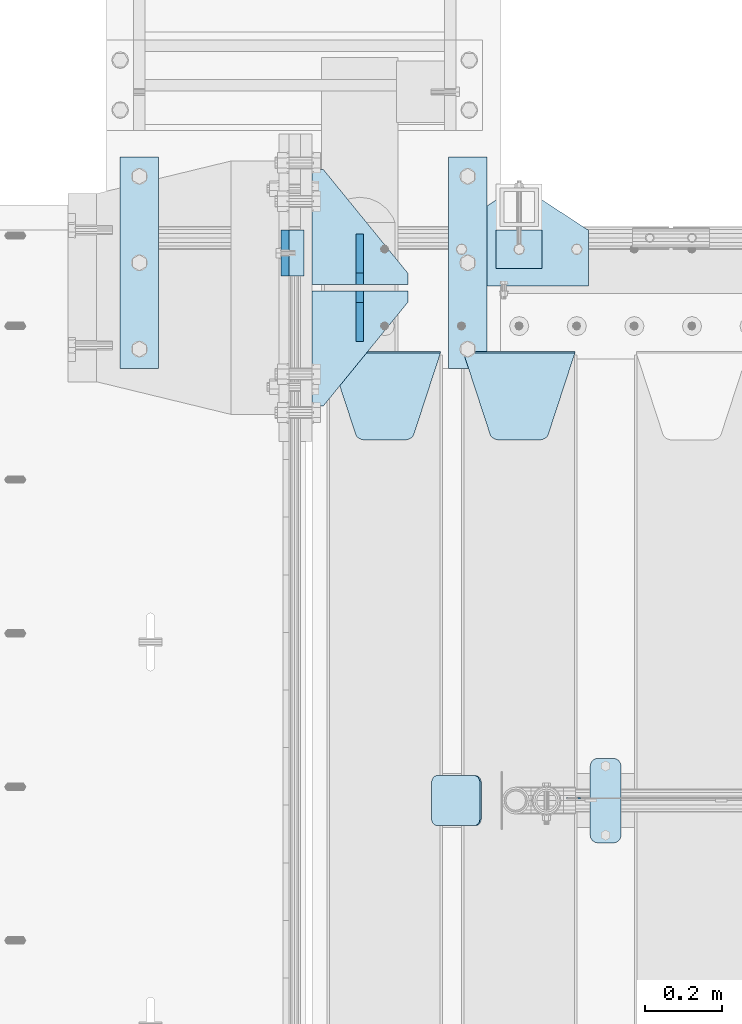
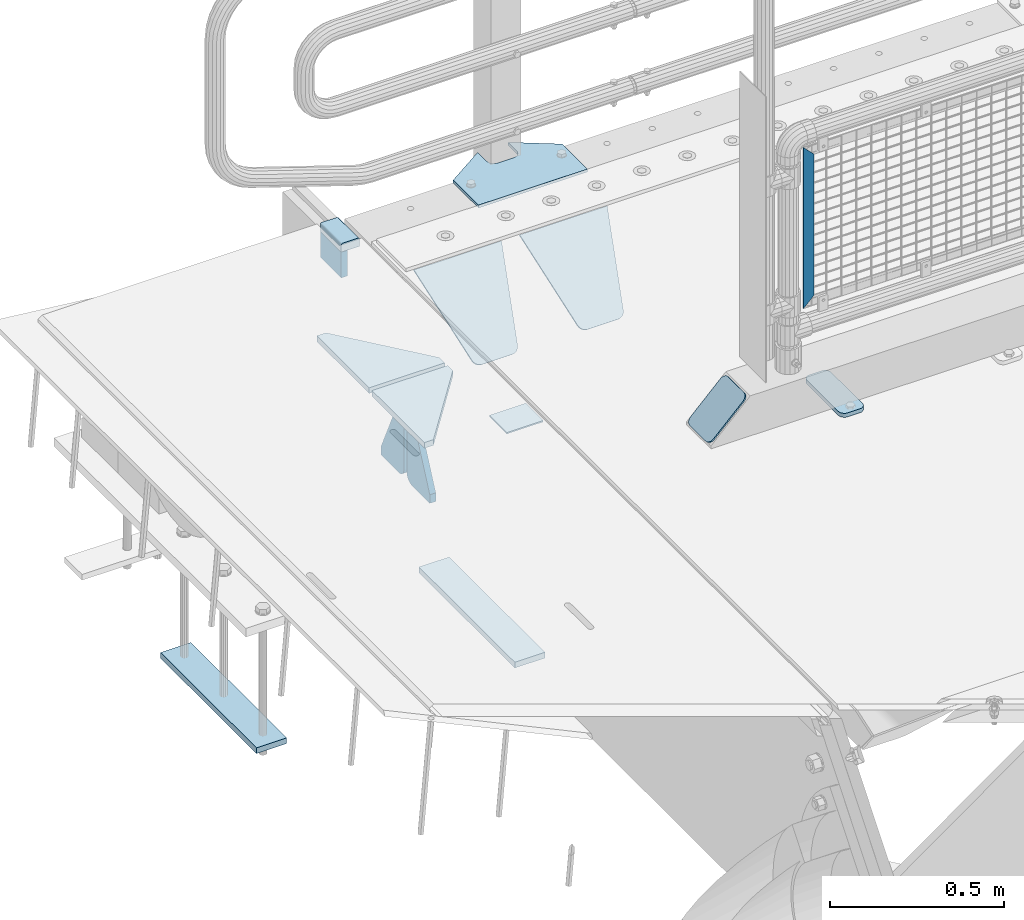
# One storey, part 212 of 247: 15 plates.
"""IFC2X3 building model written with IfcOpenShell, lengths in millimetres."""

from ifc_helpers import new_model, si_unit, frame, origin_with_axes, place, context, subcontext, project, spatial, faceted_brep, material, type_object, element, save


model = new_model("IFC2X3")

# Units and contexts
model_context = context("Model", 3, precision=1e-05, world=origin_with_axes())
body_context = subcontext(model_context, "Body", "Model", "MODEL_VIEW")
ifc_project = project(units=[si_unit("LENGTHUNIT", "METRE", prefix="MILLI"), si_unit("AREAUNIT", "SQUARE_METRE"), si_unit("VOLUMEUNIT", "CUBIC_METRE"), si_unit("MASSUNIT", "GRAM", prefix="KILO"), si_unit("TIMEUNIT", "SECOND"), si_unit("PLANEANGLEUNIT", "RADIAN"), si_unit("SOLIDANGLEUNIT", "STERADIAN"), si_unit("THERMODYNAMICTEMPERATUREUNIT", "DEGREE_CELSIUS"), si_unit("LUMINOUSINTENSITYUNIT", "LUMEN")], contexts=[model_context])

# Site, building, storey
site_placement = place(None, origin_with_axes())
site = spatial("IfcSite", under=ifc_project, at=site_placement, CompositionType="ELEMENT")
building_placement = place(site_placement, origin_with_axes())
building = spatial("IfcBuilding", under=site, at=building_placement, Name="Standard", CompositionType="ELEMENT")
storey_placement = place(building_placement, origin_with_axes())
storey = spatial("IfcBuildingStorey", under=building, at=storey_placement, Name="Undefined", CompositionType="ELEMENT", Elevation=0.0)

# Plates
ifc_material_1 = material()
plate_type_1 = type_object("IfcPlateType", PredefinedType="NOTDEFINED")
plate_1_placement = place(storey_placement, frame((-9.99999999999636, 9090.00000000002, -16.0000571412541), z_axis=(-1.0, 0.0, 0.0), x_axis=(0.0, 0.0, 1.0)))
element("IfcPlate", 1, at=plate_1_placement, inside=storey, type_object=plate_type_1, material=ifc_material_1, context=body_context, shape_type="Brep", body=[
    faceted_brep([(0.0, -59.9999999999991, 0.0), (2.49929144047201e-09, -59.9999999999991, 60.0), (2.49928788775833e-09, 60.0000000000005, 60.0), (-3.5527136788005e-15, 60.0000000000005, 0.0), (25.0146748218828, -59.9999999999991, 60.0), (25.0146748218828, 60.0000000000005, 60.0), (26.5597449794466, -59.9999999999991, 59.7552873949117), (26.5597449794466, 60.0000000000005, 59.7552873949117), (27.9535758796897, -59.9999999999991, 59.0451032832824), (27.9535758796897, 60.0000000000009, 59.0451032832824), (29.0597323263517, -59.9999999999991, 57.9389640667317), (29.0597323263517, 60.0000000000005, 57.9389640667317), (29.7699381491534, -59.9999999999991, 56.5451442289687), (29.7699381491534, 60.0000000000009, 56.5451442289687), (30.0146748212762, -59.9999999999991, 55.0000778834025), (30.0146748212762, 60.0000000000009, 55.0000778834025), (30.0154536553013, -59.9999999999991, 5.00007788340855), (30.0154536553013, 60.0000000000005, 5.00007788340855), (29.7707554908505, -59.9999999999991, 3.45497428546548), (29.7707554908505, 60.0000000000009, 3.45497428546548), (29.0605660948355, -59.9999999999991, 2.06111154407017), (29.0605660948355, 60.0000000000009, 2.06111154407017), (27.9544051209123, -59.9999999999991, 0.954933339696428), (27.9544051209123, 60.0000000000009, 0.954933339696428), (26.5605534420796, -59.9999999999991, 0.244722232012666), (26.5605534420796, 60.0000000000009, 0.244722232012666), (25.0154536559091, -59.9999999999986, 6.05382410867605e-12), (25.0154536559091, 60.0000000000009, 6.05382410867605e-12)], [[[0, 1, 2, 3]], [[1, 4, 5, 2]], [[4, 6, 7, 5]], [[6, 8, 9, 7]], [[8, 10, 11, 9]], [[10, 12, 13, 11]], [[12, 14, 15, 13]], [[14, 16, 17, 15]], [[16, 18, 19, 17]], [[18, 20, 21, 19]], [[20, 22, 23, 21]], [[22, 24, 25, 23]], [[24, 26, 27, 25]], [[26, 0, 3, 27]], [[5, 7, 9, 11, 13, 15, 17, 19, 21, 23, 25, 27, 3, 2]], [[26, 24, 22, 20, 18, 16, 14, 12, 10, 8, 6, 4, 1, 0]]]),
])
ifc_material_2 = material(Name="STEEL/S355N")
plate_type_2 = type_object("IfcPlateType", PredefinedType="NOTDEFINED")
plate_2_placement = place(storey_placement, frame((-60.0, 9150.00008553446, -105.984391681369), z_axis=(0.0, -0.999999999999548, -9.5100000000016e-07), x_axis=(0.0, 0.0, 1.0)))
element("IfcPlate", 2, at=plate_2_placement, inside=storey, type_object=plate_type_2, material=ifc_material_2, context=body_context, shape_type="Brep", body=[
    faceted_brep([(-5.6843418860808e-14, -9.99999999999989, 3.5527136788005e-15), (4.32933688898629e-10, -10.0, 120.0), (4.32933688898629e-10, 10.0, 120.0), (-5.6843418860808e-14, 10.0000000000001, 3.5527136788005e-15), (89.9845046997072, -10.0, 120.0), (89.9845046997072, 10.0, 120.0), (89.9843902587891, -10.0, 6.54836185276508e-11), (89.9843902587891, 10.0, 6.54836185276508e-11)], [[[0, 1, 2, 3]], [[1, 4, 5, 2]], [[4, 6, 7, 5]], [[6, 0, 3, 7]], [[5, 7, 3, 2]], [[6, 4, 1, 0]]]),
])
ifc_material_3 = material(Name="STEEL/S355J2")
plate_type_3 = type_object("IfcPlateType", PredefinedType="NOTDEFINED")
plate_3_placement = place(storey_placement, frame((735.0, 7774.5, 21.0199999999977), z_axis=(1.0, 0.0, 0.0), x_axis=(0.0, -0.999999999999548, -9.5100000000016e-07)))
element("IfcPlate", 3, at=plate_3_placement, inside=storey, type_object=plate_type_3, material=ifc_material_3, context=body_context, shape_type="Brep", body=[
    faceted_brep([(0.0, -7.0, 20.0), (0.0, -7.0, 60.0), (0.0, 7.0, 60.0), (0.0, 7.0, 20.0), (0.384294391935327, -7.0, 63.9018064403226), (0.384294391935327, 7.0, 63.9018064403226), (1.52240934977453, -7.0, 67.6536686473009), (1.52240934977453, 7.0, 67.6536686473009), (3.37060775394912, -7.0, 71.1114046603925), (3.37060775394912, 7.0, 71.1114046603925), (5.85786437626939, -7.0, 74.1421356237315), (5.85786437626939, 7.0, 74.1421356237315), (8.8885953396084, -7.0, 76.6293922460518), (8.8885953396084, 7.0, 76.6293922460518), (12.3463313526981, -7.0, 78.4775906502255), (12.3463313526981, 7.0, 78.4775906502255), (16.0981935596774, -7.0, 79.6157056080647), (16.0981935596774, 7.0, 79.6157056080647), (20.0, -7.0, 80.0), (20.0, 7.0, 80.0), (200.0, -7.0, 80.0), (200.0, 7.0, 80.0), (203.901806440323, -7.0, 79.6157056080647), (203.901806440323, 7.0, 79.6157056080647), (207.653668647302, -7.0, 78.4775906502255), (207.653668647302, 7.0, 78.4775906502255), (211.111404660392, -7.0, 76.6293922460518), (211.111404660392, 7.0, 76.6293922460518), (214.142135623731, -7.0, 74.1421356237315), (214.142135623731, 7.0, 74.1421356237315), (216.629392246051, -7.0, 71.1114046603925), (216.629392246051, 7.0, 71.1114046603925), (218.477590650225, -7.0, 67.6536686473009), (218.477590650225, 7.0, 67.6536686473009), (219.615705608065, -7.0, 63.9018064403226), (219.615705608065, 7.0, 63.9018064403226), (220.0, -7.0, 60.0), (220.0, 7.0, 60.0), (220.0, -7.0, 20.0), (220.0, 7.0, 20.0), (219.615705608065, -7.0, 16.0981935596774), (219.615705608065, 7.0, 16.0981935596774), (218.477590650225, -7.0, 12.3463313526991), (218.477590650225, 7.0, 12.3463313526991), (216.629392246051, -7.0, 8.88859533960749), (216.629392246051, 7.0, 8.88859533960749), (214.142135623731, -7.0, 5.85786437626848), (214.142135623731, 7.0, 5.85786437626848), (211.111404660392, -7.0, 3.37060775394821), (211.111404660392, 7.0, 3.37060775394821), (207.653668647302, -7.0, 1.52240934977453), (207.653668647302, 7.0, 1.52240934977453), (203.901806440323, -7.0, 0.384294391935327), (203.901806440323, 7.0, 0.384294391935327), (200.0, -7.0, 0.0), (200.0, 7.0, 0.0), (20.0, -7.0, 0.0), (20.0, 7.0, 0.0), (16.0981935596774, -7.0, 0.384294391935327), (16.0981935596774, 7.0, 0.384294391935327), (12.3463313526981, -7.0, 1.52240934977453), (12.3463313526981, 7.0, 1.52240934977453), (8.8885953396084, -7.0, 3.37060775394821), (8.8885953396084, 7.0, 3.37060775394821), (5.85786437626939, -7.0, 5.85786437626848), (5.85786437626939, 7.0, 5.85786437626848), (3.37060775394912, -7.0, 8.88859533960749), (3.37060775394912, 7.0, 8.88859533960749), (1.52240934977453, -7.0, 12.3463313526991), (1.52240934977453, 7.0, 12.3463313526991), (0.384294391935327, -7.0, 16.0981935596774), (0.384294391935327, 7.0, 16.0981935596774)], [[[0, 1, 2, 3]], [[1, 4, 5, 2]], [[4, 6, 7, 5]], [[6, 8, 9, 7]], [[8, 10, 11, 9]], [[10, 12, 13, 11]], [[12, 14, 15, 13]], [[14, 16, 17, 15]], [[16, 18, 19, 17]], [[18, 20, 21, 19]], [[20, 22, 23, 21]], [[22, 24, 25, 23]], [[24, 26, 27, 25]], [[26, 28, 29, 27]], [[28, 30, 31, 29]], [[30, 32, 33, 31]], [[32, 34, 35, 33]], [[34, 36, 37, 35]], [[36, 38, 39, 37]], [[38, 40, 41, 39]], [[40, 42, 43, 41]], [[42, 44, 45, 43]], [[44, 46, 47, 45]], [[46, 48, 49, 47]], [[48, 50, 51, 49]], [[50, 52, 53, 51]], [[52, 54, 55, 53]], [[54, 56, 57, 55]], [[56, 58, 59, 57]], [[58, 60, 61, 59]], [[60, 62, 63, 61]], [[62, 64, 65, 63]], [[64, 66, 67, 65]], [[66, 68, 69, 67]], [[68, 70, 71, 69]], [[70, 0, 3, 71]], [[5, 7, 9, 11, 13, 15, 17, 19, 21, 23, 25, 27, 29, 31, 33, 35, 37, 39, 41, 43, 45, 47, 49, 51, 53, 55, 57, 59, 61, 63, 65, 67, 69, 71, 3, 2]], [[70, 68, 66, 64, 62, 60, 58, 56, 54, 52, 50, 48, 46, 44, 42, 40, 38, 36, 34, 32, 30, 28, 26, 24, 22, 20, 18, 16, 14, 12, 10, 8, 6, 4, 1, 0]]]),
])
plate_type_4 = type_object("IfcPlateType", PredefinedType="NOTDEFINED")
plate_4_placement = place(storey_placement, frame((405.0, 8831.76776695594, -1.767766952965), z_axis=(0.0, -0.707106781186548, -0.707106781186547), x_axis=(1.0, 0.0, 0.0)))
element("IfcPlate", 4, at=plate_4_placement, inside=storey, type_object=plate_type_4, material=ifc_material_2, context=body_context, shape_type="Brep", body=[
    faceted_brep([(0.0, -2.49999999999909, 0.0), (69.345504679477, -2.5, 300.17173142483), (69.345504679477, 2.50000000000091, 300.171731424831), (0.0, 2.5, -9.09494701772928e-13), (70.9274061199576, -2.5, 304.897442415399), (70.9274061199576, 2.50000000000091, 304.8974424154), (73.3818627772307, -2.49999999999909, 309.234538108527), (73.3818627772307, 2.5, 309.234538108526), (76.6187032999551, -2.5, 313.023683126102), (76.6187032999551, 2.50000000000091, 313.023683126102), (80.5190132704993, -2.49999999999909, 316.125672595371), (80.5190132704993, 2.50000000000091, 316.125672595372), (84.9395038596849, -2.49999999999909, 318.426546230476), (84.9395038596849, 2.5, 318.426546230475), (89.7177759439219, -2.5, 319.841774983274), (89.7177759439219, 2.50000000000091, 319.841774983275), (94.678286292652, -2.5, 320.319366455077), (94.678286292652, 2.50000000000091, 320.319366455077), (195.321713707348, -2.5, 320.319366455077), (195.321713707348, 2.50000000000091, 320.319366455077), (200.282224056078, -2.5, 319.841774983274), (200.282224056078, 2.50000000000091, 319.841774983275), (205.060496140315, -2.5, 318.426546230475), (205.060496140315, 2.5, 318.426546230474), (209.480986729501, -2.49999999999818, 316.12567259537), (209.480986729501, 2.50000000000091, 316.12567259537), (213.381296700045, -2.5, 313.023683126101), (213.381296700045, 2.50000000000091, 313.023683126101), (216.618137222769, -2.5, 309.234538108525), (216.618137222769, 2.5, 309.234538108525), (219.072593880042, -2.49999999999909, 304.897442415398), (219.072593880042, 2.5, 304.897442415398), (220.654495320523, -2.5, 300.17173142483), (220.654495320523, 2.50000000000091, 300.171731424831), (290.0, -2.49999999999909, 0.0), (290.0, 2.5, -9.09494701772928e-13)], [[[0, 1, 2, 3]], [[1, 4, 5, 2]], [[4, 6, 7, 5]], [[6, 8, 9, 7]], [[8, 10, 11, 9]], [[10, 12, 13, 11]], [[12, 14, 15, 13]], [[14, 16, 17, 15]], [[16, 18, 19, 17]], [[18, 20, 21, 19]], [[20, 22, 23, 21]], [[22, 24, 25, 23]], [[24, 26, 27, 25]], [[26, 28, 29, 27]], [[28, 30, 31, 29]], [[30, 32, 33, 31]], [[32, 34, 35, 33]], [[34, 0, 3, 35]], [[5, 7, 9, 11, 13, 15, 17, 19, 21, 23, 25, 27, 29, 31, 33, 35, 3, 2]], [[34, 32, 30, 28, 26, 24, 22, 20, 18, 16, 14, 12, 10, 8, 6, 4, 1, 0]]]),
])
plate_5_placement = place(storey_placement, frame((55.0, 8831.76776695594, -1.767766952965), z_axis=(0.0, -0.707106781186548, -0.707106781186547), x_axis=(1.0, 0.0, 0.0)))
element("IfcPlate", 5, at=plate_5_placement, inside=storey, type_object=plate_type_4, material=ifc_material_2, context=body_context, shape_type="Brep", body=[
    faceted_brep([(0.0, -2.49999999999909, 0.0), (69.345504679477, -2.5, 300.17173142483), (69.345504679477, 2.50000000000091, 300.171731424831), (0.0, 2.5, -9.09494701772928e-13), (70.9274061199576, -2.5, 304.897442415399), (70.9274061199576, 2.50000000000091, 304.8974424154), (73.3818627772307, -2.49999999999909, 309.234538108527), (73.3818627772307, 2.5, 309.234538108526), (76.6187032999551, -2.5, 313.023683126102), (76.6187032999551, 2.50000000000091, 313.023683126102), (80.5190132704993, -2.49999999999909, 316.125672595371), (80.5190132704993, 2.50000000000091, 316.125672595372), (84.9395038596849, -2.49999999999909, 318.426546230476), (84.9395038596849, 2.5, 318.426546230475), (89.7177759439219, -2.5, 319.841774983274), (89.7177759439219, 2.50000000000091, 319.841774983275), (94.678286292652, -2.5, 320.319366455077), (94.678286292652, 2.50000000000091, 320.319366455077), (195.321713707348, -2.5, 320.319366455077), (195.321713707348, 2.50000000000091, 320.319366455077), (200.282224056078, -2.5, 319.841774983274), (200.282224056078, 2.50000000000091, 319.841774983275), (205.060496140315, -2.5, 318.426546230475), (205.060496140315, 2.5, 318.426546230474), (209.480986729501, -2.49999999999818, 316.12567259537), (209.480986729501, 2.50000000000091, 316.12567259537), (213.381296700045, -2.5, 313.023683126101), (213.381296700045, 2.50000000000091, 313.023683126101), (216.618137222769, -2.5, 309.234538108525), (216.618137222769, 2.5, 309.234538108525), (219.072593880042, -2.49999999999909, 304.897442415398), (219.072593880042, 2.5, 304.897442415398), (220.654495320523, -2.5, 300.17173142483), (220.654495320523, 2.50000000000091, 300.171731424831), (290.0, -2.49999999999909, 0.0), (290.0, 2.5, -9.09494701772928e-13)], [[[0, 1, 2, 3]], [[1, 4, 5, 2]], [[4, 6, 7, 5]], [[6, 8, 9, 7]], [[8, 10, 11, 9]], [[10, 12, 13, 11]], [[12, 14, 15, 13]], [[14, 16, 17, 15]], [[16, 18, 19, 17]], [[18, 20, 21, 19]], [[20, 22, 23, 21]], [[22, 24, 25, 23]], [[24, 26, 27, 25]], [[26, 28, 29, 27]], [[28, 30, 31, 29]], [[30, 32, 33, 31]], [[32, 34, 35, 33]], [[34, 0, 3, 35]], [[5, 7, 9, 11, 13, 15, 17, 19, 21, 23, 25, 27, 29, 31, 33, 35, 3, 2]], [[34, 32, 30, 28, 26, 24, 22, 20, 18, 16, 14, 12, 10, 8, 6, 4, 1, 0]]]),
])
plate_type_5 = type_object("IfcPlateType", PredefinedType="NOTDEFINED")
for number, where, z_axis, x_axis in (
    (6, (-488.999999999987, 9339.99999928438, -1468.0), (0.0, -0.999999999999548, -9.5100000000016e-07), (1.0, 0.0, 0.0)),
    (7, (366.000000000013, 9340.00000013937, -1468.0), (0.0, -0.999999999999548, -9.5100000000016e-07), (1.0, 0.0, 0.0)),
):
    element("IfcPlate", number, at=place(storey_placement, frame(where, z_axis=z_axis, x_axis=x_axis)), inside=storey, type_object=plate_type_5, material=ifc_material_2, context=body_context, shape_type="Brep", body=[
        faceted_brep([(-5.6843418860808e-14, -9.99999999999989, 3.5527136788005e-15), (1.00943600500614e-06, -10.0, 550.0), (1.00943600500614e-06, 10.0, 550.0), (-5.6843418860808e-14, 10.0000000000001, 3.5527136788005e-15), (100.000000000004, -10.0, 550.0), (100.000000000004, 10.0, 550.0), (100.0, -10.0, 0.0), (100.0, 10.0, 0.0)], [[[0, 1, 2, 3]], [[1, 4, 5, 2]], [[4, 6, 7, 5]], [[6, 0, 3, 7]], [[5, 7, 3, 2]], [[6, 4, 1, 0]]]),
    ])
ifc_material_4 = material(Name="Misc_Undefined")
plate_type_6 = type_object("IfcPlateType", PredefinedType="NOTDEFINED")
plate_6_placement = place(storey_placement, frame((709.509713540967, 7670.5, 879.519963133601), z_axis=(-0.707008801899319, 0.0, -0.707204746899291), x_axis=(-0.707204746899294, 0.0, 0.707008801899315)))
element("IfcPlate", 8, at=plate_6_placement, inside=storey, type_object=plate_type_6, material=ifc_material_4, context=body_context, shape_type="Brep", body=[
    faceted_brep([(1.81898940354586e-12, -1.5, -5.6843418860808e-14), (-348.552185058596, -1.5, 348.655029296875), (-348.552185058596, 1.5, 348.655029296875), (1.81898940354586e-12, 1.5, -5.6843418860808e-14), (-348.544891357424, -1.5, 398.152496337891), (-348.544891357424, 1.5, 398.152496337891), (49.50439453125, -1.5, 7.6397554948926e-11), (49.50439453125, 1.5, 7.6397554948926e-11)], [[[0, 1, 2, 3]], [[1, 4, 5, 2]], [[4, 6, 7, 5]], [[6, 0, 3, 7]], [[5, 7, 3, 2]], [[6, 4, 1, 0]]]),
])
plate_type_7 = type_object("IfcPlateType", PredefinedType="NOTDEFINED")
for number, where, z_axis, x_axis in (
    (9, (259.999999999996, 9008.0, -515.0), (0.0, 1.0, 0.0), (-1.0, 0.0, 0.0)),
    (10, (259.999999999996, 8992.0, -515.0), (0.0, -0.999999999999548, -9.5100000000016e-07), (-1.0, 0.0, 0.0)),
):
    element("IfcPlate", number, at=place(storey_placement, frame(where, z_axis=z_axis, x_axis=x_axis)), inside=storey, type_object=plate_type_7, material=ifc_material_2, context=body_context, shape_type="Brep", body=[
        faceted_brep([(-5.6843418860808e-14, -9.99999999999989, 3.5527136788005e-15), (0.0, -10.0, 30.0), (0.0, 10.0, 30.0), (-5.6843418860808e-14, 10.0000000000001, 3.5527136788005e-15), (220.0, -10.0, 300.0), (220.0, 10.0, 300.0), (250.0, -10.0, 300.0), (250.0, 10.0, 300.0), (250.0, -10.0, 0.0), (250.0, 10.0, 0.0)], [[[0, 1, 2, 3]], [[1, 4, 5, 2]], [[4, 6, 7, 5]], [[6, 8, 9, 7]], [[8, 0, 3, 9]], [[5, 7, 9, 3, 2]], [[8, 6, 4, 1, 0]]]),
    ])
plate_type_8 = type_object("IfcPlateType", PredefinedType="NOTDEFINED")
for number, where, z_axis, x_axis in (
    (11, (135.0, 9140.0, -860.0), (0.0, 0.0, 1.0), (0.0, -0.999999999999548, -9.5100000000016e-07)),
    (12, (135.0, 8860.0, -860.0), (0.0, 0.0, 1.0), (0.0, 1.0, 0.0)),
):
    element("IfcPlate", number, at=place(storey_placement, frame(where, z_axis=z_axis, x_axis=x_axis)), inside=storey, type_object=plate_type_8, material=ifc_material_2, context=body_context, shape_type="Brep", body=[
        faceted_brep([(-5.6843418860808e-14, -9.99999999999989, 3.5527136788005e-15), (0.0, -10.0, 30.0), (0.0, 10.0, 30.0), (-5.6843418860808e-14, 10.0000000000001, 3.5527136788005e-15), (102.0, -10.0, 250.0), (102.0, 10.0, 250.0), (132.0, -10.0, 250.0), (132.0, 10.0, 250.0), (132.0, -10.0, 30.0), (132.0, 10.0, 30.0), (131.544232590366, -10.0, 24.790554669992), (131.544232590366, 10.0, 24.790554669992), (130.190778623577, -10.0, 19.7393957002299), (130.190778623577, 10.0, 19.7393957002299), (127.980762113533, -10.0, 15.0), (127.980762113533, 10.0, 15.0), (124.981333293569, -10.0, 10.7163717094038), (124.981333293569, 10.0, 10.7163717094038), (121.283628290596, -10.0, 7.01866670643062), (121.283628290596, 10.0, 7.01866670643062), (117.0, -10.0, 4.01923788646684), (117.0, 10.0, 4.01923788646684), (112.26060429977, -10.0, 1.80922137642278), (112.26060429977, 10.0, 1.80922137642278), (107.209445330008, -10.0, 0.455767409633722), (107.209445330008, 10.0, 0.455767409633722), (102.0, -10.0, 0.0), (102.0, 10.0, 0.0)], [[[0, 1, 2, 3]], [[1, 4, 5, 2]], [[4, 6, 7, 5]], [[6, 8, 9, 7]], [[8, 10, 11, 9]], [[10, 12, 13, 11]], [[12, 14, 15, 13]], [[14, 16, 17, 15]], [[16, 18, 19, 17]], [[18, 20, 21, 19]], [[20, 22, 23, 21]], [[22, 24, 25, 23]], [[24, 26, 27, 25]], [[26, 0, 3, 27]], [[5, 7, 9, 11, 13, 15, 17, 19, 21, 23, 25, 27, 3, 2]], [[26, 24, 22, 20, 18, 16, 14, 12, 10, 8, 6, 4, 1, 0]]]),
    ])
plate_type_9 = type_object("IfcPlateType", PredefinedType="NOTDEFINED")
plate_7_placement = place(storey_placement, frame((370.0, 9005.0, 5.00000000004911), z_axis=(0.0, 1.0, 0.0), x_axis=(1.0, 0.0, 0.0)))
element("IfcPlate", 13, at=plate_7_placement, inside=storey, type_object=plate_type_9, material=ifc_material_3, context=body_context, shape_type="Brep", body=[
    faceted_brep([(9.04219632502645e-09, -5.00000000143385, -2.89173840428703e-09), (2.31396552408114e-06, -5.0, 145.0), (2.31396552408114e-06, 5.0, 145.0), (7.66340235713869e-09, 4.99999999856618, -2.89173840428703e-09), (130.0, -5.0, 230.0), (130.0, 5.0, 230.0), (130.0, -5.0, 180.0), (130.0, 5.0, 180.0), (130.48036798992, -5.0, 175.122741949597), (130.48036798992, 5.0, 175.122741949597), (131.903011687218, -5.0, 170.432914190873), (131.903011687218, 5.0, 170.432914190873), (134.213259692437, -5.0, 166.11074417451), (134.213259692437, 5.0, 166.11074417451), (137.322330470337, -5.0, 162.322330470337), (137.322330470337, 5.0, 162.322330470337), (141.11074417451, -5.0, 159.213259692437), (141.11074417451, 5.0, 159.213259692437), (145.432914190873, -5.0, 156.903011687218), (145.432914190873, 5.0, 156.903011687218), (150.122741949597, -5.0, 155.48036798992), (150.122741949597, 5.0, 155.48036798992), (155.0, -5.0, 155.0), (155.0, 5.0, 155.0), (205.0, -5.0, 155.0), (205.0, 5.0, 155.0), (209.877258050403, -5.0, 155.48036798992), (209.877258050403, 5.0, 155.48036798992), (214.567085809127, -5.0, 156.903011687218), (214.567085809127, 5.0, 156.903011687218), (218.88925582549, -5.0, 159.213259692437), (218.88925582549, 5.0, 159.213259692437), (222.677669529663, -5.0, 162.322330470337), (222.677669529663, 5.0, 162.322330470337), (225.786740307563, -5.0, 166.11074417451), (225.786740307563, 5.0, 166.11074417451), (228.096988312782, -5.0, 170.432914190873), (228.096988312782, 5.0, 170.432914190873), (229.51963201008, -5.0, 175.122741949597), (229.51963201008, 5.0, 175.122741949597), (230.0, -5.0, 180.0), (230.0, 5.0, 180.0), (230.0, -5.0, 230.0), (230.0, 5.0, 230.0), (360.0, -5.0, 145.0), (360.0, 5.0, 145.0), (360.0, -5.0, -7.27595761418343e-12), (360.0, 5.0, -7.27595761418343e-12)], [[[0, 1, 2, 3]], [[1, 4, 5, 2]], [[4, 6, 7, 5]], [[6, 8, 9, 7]], [[8, 10, 11, 9]], [[10, 12, 13, 11]], [[12, 14, 15, 13]], [[14, 16, 17, 15]], [[16, 18, 19, 17]], [[18, 20, 21, 19]], [[20, 22, 23, 21]], [[22, 24, 25, 23]], [[24, 26, 27, 25]], [[26, 28, 29, 27]], [[28, 30, 31, 29]], [[30, 32, 33, 31]], [[32, 34, 35, 33]], [[34, 36, 37, 35]], [[36, 38, 39, 37]], [[38, 40, 41, 39]], [[40, 42, 43, 41]], [[42, 44, 45, 43]], [[44, 46, 47, 45]], [[46, 0, 3, 47]], [[5, 7, 9, 11, 13, 15, 17, 19, 21, 23, 25, 27, 29, 31, 33, 35, 37, 39, 41, 43, 45, 47, 3, 2]], [[46, 44, 42, 40, 38, 36, 34, 32, 30, 28, 26, 24, 22, 20, 18, 16, 14, 12, 10, 8, 6, 4, 1, 0]]]),
])
plate_type_10 = type_object("IfcPlateType", PredefinedType="NOTDEFINED")
plate_8_placement = place(storey_placement, frame((490.000000000138, 9050.00000000021, -857.500000000002), z_axis=(0.0, 1.0, 0.0), x_axis=(1.0, 0.0, 0.0)))
element("IfcPlate", 14, at=plate_8_placement, inside=storey, type_object=plate_type_10, material=ifc_material_3, context=body_context, shape_type="Brep", body=[
    faceted_brep([(0.0, -2.49999999999909, 0.0), (0.0, -2.5, 100.0), (0.0, 2.5, 100.0), (0.0, 2.5, -9.09494701772928e-13), (120.0, -2.5, 100.0), (120.0, 2.5, 100.0), (120.0, -2.5, 0.0), (120.0, 2.5, 0.0)], [[[0, 1, 2, 3]], [[1, 4, 5, 2]], [[4, 6, 7, 5]], [[6, 0, 3, 7]], [[5, 7, 3, 2]], [[6, 4, 1, 0]]]),
])
plate_type_11 = type_object("IfcPlateType", PredefinedType="NOTDEFINED")
plate_9_placement = place(storey_placement, frame((449.80758152104, 7729.5, 166.254400376568), z_axis=(-0.707410512925777, 0.0, -0.706802918925841), x_axis=(0.0, -0.999999999999548, -9.5100000000016e-07)))
element("IfcPlate", 15, at=plate_9_placement, inside=storey, type_object=plate_type_11, material=ifc_material_3, context=body_context, shape_type="Brep", body=[
    faceted_brep([(0.0, -2.50000000000182, 20.0), (0.0, -2.50000000000182, 158.926651000977), (0.0, 2.49999999999818, 158.926651000977), (0.0, 2.49999999999818, 20.0), (0.384294391935327, -2.50000000000182, 162.828457441299), (0.384294391935327, 2.49999999999818, 162.828457441299), (1.52240934977453, -2.5, 166.580319648279), (1.52240934977453, 2.49999999999818, 166.580319648279), (3.37060775394912, -2.5, 170.038055661367), (3.37060775394912, 2.49999999999818, 170.038055661367), (5.85786437626939, -2.5, 173.068786624706), (5.85786437626939, 2.49999999999818, 173.068786624706), (8.8885953396084, -2.50000000000182, 175.556043247028), (8.8885953396084, 2.49999999999818, 175.556043247027), (12.3463313526981, -2.5, 177.404241651202), (12.3463313526981, 2.49999999999818, 177.404241651202), (16.0981935596774, -2.50000000000182, 178.542356609041), (16.0981935596774, 2.49999999999818, 178.542356609041), (20.0, -2.50000000000182, 178.926651000977), (20.0, 2.49999999999818, 178.926651000975), (110.0, -2.50000000000182, 178.926651000977), (110.0, 2.49999999999818, 178.926651000975), (113.901806440323, -2.50000000000182, 178.542356609041), (113.901806440323, 2.49999999999818, 178.542356609041), (117.653668647302, -2.5, 177.404241651202), (117.653668647302, 2.49999999999818, 177.404241651202), (121.111404660392, -2.50000000000182, 175.556043247028), (121.111404660392, 2.49999999999818, 175.556043247027), (124.142135623731, -2.5, 173.068786624706), (124.142135623731, 2.49999999999818, 173.068786624706), (126.629392246051, -2.5, 170.038055661367), (126.629392246051, 2.49999999999818, 170.038055661367), (128.477590650225, -2.5, 166.580319648279), (128.477590650225, 2.49999999999818, 166.580319648279), (129.615705608065, -2.50000000000182, 162.828457441299), (129.615705608065, 2.49999999999818, 162.828457441299), (130.0, -2.50000000000182, 158.926651000977), (130.0, 2.49999999999818, 158.926651000977), (130.0, -2.50000000000182, 20.0), (130.0, 2.49999999999818, 20.0), (129.615705608065, -2.50000000000182, 16.0981935596774), (129.615705608065, 2.5, 16.0981935596774), (128.477590650225, -2.50000000000182, 12.3463313526972), (128.477590650225, 2.49999999999818, 12.3463313526991), (126.629392246051, -2.50000000000182, 8.88859533960749), (126.629392246051, 2.5, 8.88859533960749), (124.142135623731, -2.50000000000364, 5.85786437626848), (124.142135623731, 2.5, 5.85786437626848), (121.111404660392, -2.50000000000182, 3.37060775394821), (121.111404660392, 2.49999999999818, 3.37060775395003), (117.653668647302, -2.50000000000182, 1.52240934977453), (117.653668647302, 2.49999999999818, 1.52240934977272), (113.901806440323, -2.50000000000182, 0.384294391935327), (113.901806440323, 2.49999999999818, 0.384294391935327), (110.0, -2.50000000000182, -1.81898940354586e-12), (110.0, 2.49999999999818, 0.0), (20.0, -2.50000000000182, -1.81898940354586e-12), (20.0, 2.49999999999818, 0.0), (16.0981935596774, -2.50000000000182, 0.384294391935327), (16.0981935596774, 2.49999999999818, 0.384294391935327), (12.3463313526981, -2.50000000000182, 1.52240934977453), (12.3463313526981, 2.49999999999818, 1.52240934977272), (8.8885953396084, -2.50000000000182, 3.37060775394821), (8.8885953396084, 2.49999999999818, 3.37060775395003), (5.85786437626939, -2.50000000000364, 5.85786437626848), (5.85786437626939, 2.5, 5.85786437626848), (3.37060775394912, -2.50000000000182, 8.88859533960749), (3.37060775394912, 2.5, 8.88859533960749), (1.52240934977453, -2.50000000000182, 12.3463313526972), (1.52240934977453, 2.49999999999818, 12.3463313526991), (0.384294391935327, -2.50000000000182, 16.0981935596774), (0.384294391935327, 2.5, 16.0981935596774)], [[[0, 1, 2, 3]], [[1, 4, 5, 2]], [[4, 6, 7, 5]], [[6, 8, 9, 7]], [[8, 10, 11, 9]], [[10, 12, 13, 11]], [[12, 14, 15, 13]], [[14, 16, 17, 15]], [[16, 18, 19, 17]], [[18, 20, 21, 19]], [[20, 22, 23, 21]], [[22, 24, 25, 23]], [[24, 26, 27, 25]], [[26, 28, 29, 27]], [[28, 30, 31, 29]], [[30, 32, 33, 31]], [[32, 34, 35, 33]], [[34, 36, 37, 35]], [[36, 38, 39, 37]], [[38, 40, 41, 39]], [[40, 42, 43, 41]], [[42, 44, 45, 43]], [[44, 46, 47, 45]], [[46, 48, 49, 47]], [[48, 50, 51, 49]], [[50, 52, 53, 51]], [[52, 54, 55, 53]], [[54, 56, 57, 55]], [[56, 58, 59, 57]], [[58, 60, 61, 59]], [[60, 62, 63, 61]], [[62, 64, 65, 63]], [[64, 66, 67, 65]], [[66, 68, 69, 67]], [[68, 70, 71, 69]], [[70, 0, 3, 71]], [[5, 7, 9, 11, 13, 15, 17, 19, 21, 23, 25, 27, 29, 31, 33, 35, 37, 39, 41, 43, 45, 47, 49, 51, 53, 55, 57, 59, 61, 63, 65, 67, 69, 71, 3, 2]], [[70, 68, 66, 64, 62, 60, 58, 56, 54, 52, 50, 48, 46, 44, 42, 40, 38, 36, 34, 32, 30, 28, 26, 24, 22, 20, 18, 16, 14, 12, 10, 8, 6, 4, 1, 0]]]),
])

save(model, "model.ifc")
